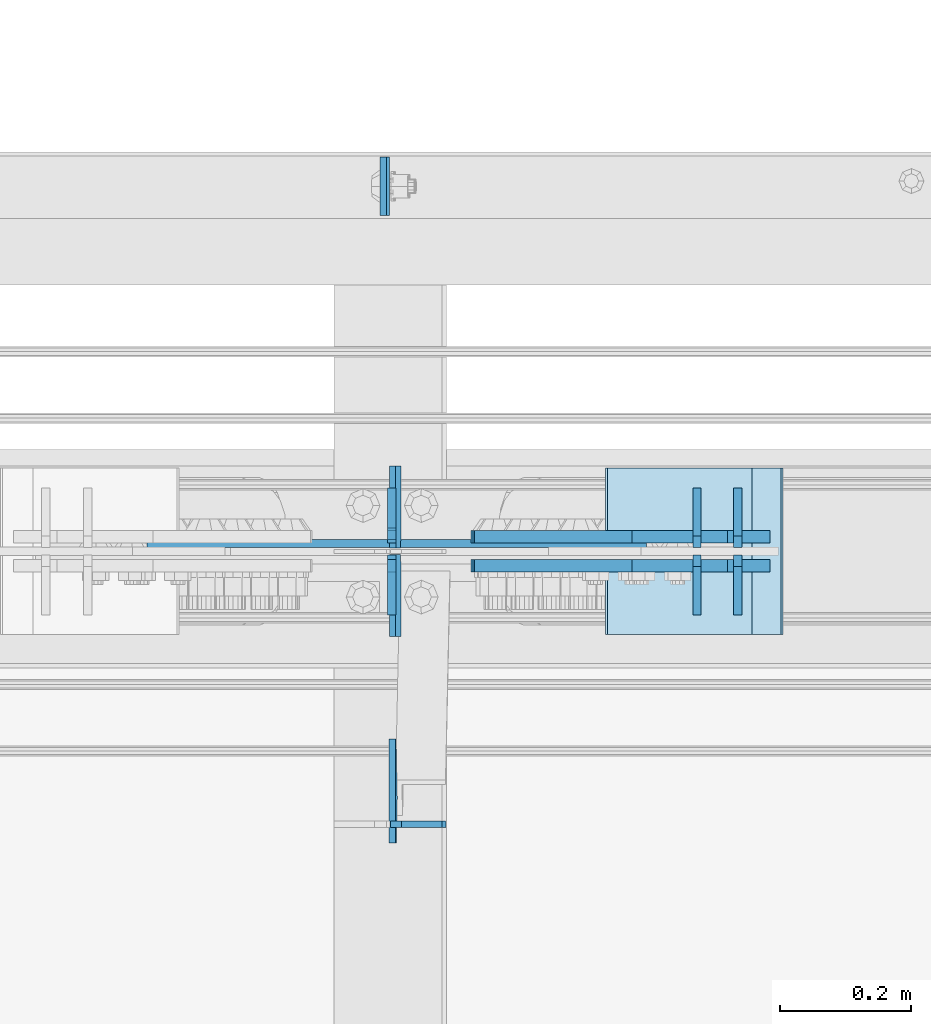
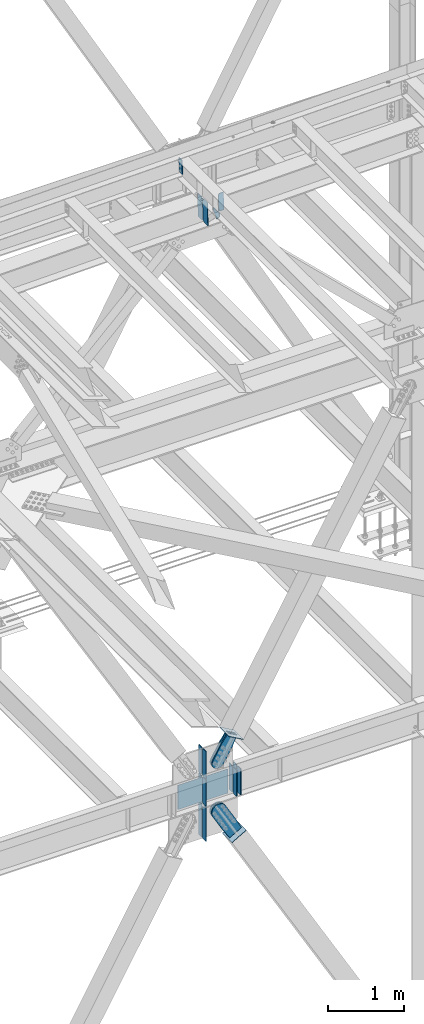
# One storey, part 3471 of 3843: 22 plates, 10 elements without a shape of their own.
"""IFC2X3 building model written with IfcOpenShell, lengths in millimetres."""

from ifc_helpers import new_model, si_unit, frame, origin_with_axes, place, context, subcontext, project, spatial, faceted_brep, material, type_object, element, aggregate, save


model = new_model("IFC2X3")

# Units and contexts
model_context = context("Model", 3, precision=1e-05, world=origin_with_axes())
body_context = subcontext(model_context, "Body", "Model", "MODEL_VIEW")
ifc_project = project(units=[si_unit("LENGTHUNIT", "METRE", prefix="MILLI"), si_unit("AREAUNIT", "SQUARE_METRE"), si_unit("VOLUMEUNIT", "CUBIC_METRE"), si_unit("MASSUNIT", "GRAM", prefix="KILO"), si_unit("TIMEUNIT", "SECOND"), si_unit("PLANEANGLEUNIT", "RADIAN"), si_unit("SOLIDANGLEUNIT", "STERADIAN"), si_unit("THERMODYNAMICTEMPERATUREUNIT", "DEGREE_CELSIUS"), si_unit("LUMINOUSINTENSITYUNIT", "LUMEN")], contexts=[model_context])

# Site, building, storey
site_placement = place(None, origin_with_axes())
site = spatial("IfcSite", under=ifc_project, at=site_placement, CompositionType="ELEMENT")
building_placement = place(site_placement, origin_with_axes())
building = spatial("IfcBuilding", under=site, at=building_placement, Name="Undefined", CompositionType="ELEMENT")
storey_placement = place(building_placement, origin_with_axes())
storey = spatial("IfcBuildingStorey", under=building, at=storey_placement, Name="Undefined", CompositionType="ELEMENT", Elevation=0.0)

# Assembly, plate
assembly_1_placement = place(storey_placement, origin_with_axes())
assembly_1 = element("IfcElementAssembly", 1, at=assembly_1_placement, inside=storey, Name="CHANNEL", AssemblyPlace="NOTDEFINED", PredefinedType="RIGID_FRAME")
ifc_material_1 = material(Name="STEEL/A572-50")
plate_type_1 = type_object("IfcPlateType", PredefinedType="NOTDEFINED")
plate_1_placement = place(assembly_1_placement, frame((52449.9878805814, 92816.3624116129, 46027.3749130814), z_axis=(1.85699999689158e-05, -0.999999999827578, 0.0), x_axis=(0.0211520550054438, 0.0, -0.999776270257025)))
plate_1 = element("IfcPlate", 2, at=plate_1_placement, type_object=plate_type_1, material=ifc_material_1, Name="PLATE", context=body_context, shape_type="Brep", body=[
    faceted_brep([(0.0, -4.76249999999709, 0.0), (0.0, -4.76249999999709, 88.9000015258789), (0.0, 4.76249999999709, 88.9000015258789), (0.0, 4.76249999999709, 0.0), (228.600006102781, -4.7625000004191, 88.9000015257589), (228.600006102781, 4.76249999954598, 88.9000015257443), (228.600006103079, -4.7625000004482, 7.27595761418343e-12), (228.600006103079, 4.76249999954598, -7.27595761418343e-12)], [[[0, 1, 2, 3]], [[1, 4, 5, 2]], [[4, 6, 7, 5]], [[6, 0, 3, 7]], [[5, 7, 3, 2]], [[6, 4, 1, 0]]]),
])
aggregate(assembly_1, [plate_1])

# Assembly, plates
assembly_2_placement = place(storey_placement, origin_with_axes())
assembly_2 = element("IfcElementAssembly", 3, at=assembly_2_placement, inside=storey, Name="BEAM", AssemblyPlace="NOTDEFINED", PredefinedType="RIGID_FRAME")
plate_type_2 = type_object("IfcPlateType", PredefinedType="NOTDEFINED")
plate_2_placement = place(assembly_2_placement, frame((52472.0350760633, 92084.525, 45357.7209272151), z_axis=(-0.0211520980073474, 0.0, 0.999776269347241), x_axis=(0.0, 1.0, 0.0)))
plate_2 = element("IfcPlate", 4, at=plate_2_placement, type_object=plate_type_2, material=ifc_material_1, Name="STIFFENER", context=body_context, shape_type="Brep", body=[
    faceted_brep([(0.0, -4.76249999999709, 0.0), (0.0, -4.76249999999709, 377.824999997538), (0.0, 4.76249999999709, 377.824999997538), (0.0, 4.76249999999709, 0.0), (103.187499618536, -4.76249999999709, 377.824999997538), (103.187499618536, 4.76249999999709, 377.824999997538), (125.412500000006, -4.76249999999709, 355.599999616068), (125.412500000006, 4.76249999999709, 355.599999616068), (125.412500000006, -4.76249999999709, 22.2250003814697), (125.412500000006, 4.76249999999709, 22.2250003814697), (103.187499618536, -4.76249999999709, 0.0), (103.187499618536, 4.76249999999709, 0.0)], [[[0, 1, 2, 3]], [[1, 4, 5, 2]], [[4, 6, 7, 5]], [[6, 8, 9, 7]], [[8, 10, 11, 9]], [[10, 0, 3, 11]], [[5, 7, 9, 11, 3, 2]], [[10, 8, 6, 4, 1, 0]]]),
])
plate_3_placement = place(assembly_2_placement, frame((52472.0350760633, 92219.4625, 45357.7209272151), z_axis=(-0.0211520980073474, 0.0, 0.999776269347241), x_axis=(0.0, 1.0, 0.0)))
plate_3 = element("IfcPlate", 5, at=plate_3_placement, type_object=plate_type_2, material=ifc_material_1, Name="STIFFENER", context=body_context, shape_type="Brep", body=[
    faceted_brep([(0.0, -4.76249999999709, 22.2250003814697), (0.0, -4.76249999999709, 355.599999616068), (0.0, 4.76249999999709, 355.599999616068), (0.0, 4.76249999999709, 22.2250003814697), (22.2250003814697, -4.76249999999709, 377.824999997538), (22.2250003814697, 4.76249999999709, 377.824999997538), (125.412500000006, -4.76249999999709, 377.824999997538), (125.412500000006, 4.76249999999709, 377.824999997538), (125.412500000006, -4.76249999999709, 0.0), (125.412500000006, 4.76249999999709, 0.0), (22.2250003814697, -4.76249999999709, 0.0), (22.2250003814697, 4.76249999999709, 0.0)], [[[0, 1, 2, 3]], [[1, 4, 5, 2]], [[4, 6, 7, 5]], [[6, 8, 9, 7]], [[8, 10, 11, 9]], [[10, 0, 3, 11]], [[5, 7, 9, 11, 3, 2]], [[10, 8, 6, 4, 1, 0]]]),
])
aggregate(assembly_2, [plate_2, plate_3])

assembly_3_placement = place(storey_placement, origin_with_axes())
assembly_3 = element("IfcElementAssembly", 6, at=assembly_3_placement, inside=storey, Name="BEAM", AssemblyPlace="NOTDEFINED", PredefinedType="RIGID_FRAME")
plate_type_3 = type_object("IfcPlateType", PredefinedType="NOTDEFINED")
plate_4_placement = place(assembly_3_placement, frame((52990.8604782097, 92220.25625, 35990.2125), z_axis=(0.0, 1.0, 0.0), x_axis=(0.0, 0.0, 1.0)))
plate_4 = element("IfcPlate", 7, at=plate_4_placement, type_object=plate_type_3, material=ifc_material_1, Name="CB_BEAM", context=body_context, shape_type="Brep", body=[
    faceted_brep([(0.0, -6.34999999999854, 17.4624996185303), (0.0, -6.34999999999854, 91.28125), (0.0, 6.34999999999854, 91.28125), (0.0, 6.34999999999854, 17.4624996185303), (425.449999999997, -6.34999999999854, 91.28125), (425.449999999997, 6.34999999999854, 91.28125), (425.449999999997, -6.34999999999854, 17.4624996185303), (425.449999999997, 6.34999999999854, 17.4624996185303), (407.987500381467, -6.34999999999854, 0.0), (407.987500381467, 6.34999999999854, 0.0), (17.4624996185303, -6.34999999999854, 0.0), (17.4624996185303, 6.34999999999854, 0.0)], [[[0, 1, 2, 3]], [[1, 4, 5, 2]], [[4, 6, 7, 5]], [[6, 8, 9, 7]], [[8, 10, 11, 9]], [[10, 0, 3, 11]], [[5, 7, 9, 11, 3, 2]], [[10, 8, 6, 4, 1, 0]]]),
])
plate_5_placement = place(assembly_3_placement, frame((52990.8604782097, 92209.14375, 35990.2125), z_axis=(0.0, -1.0, 0.0), x_axis=(0.0, 0.0, 1.0)))
plate_5 = element("IfcPlate", 8, at=plate_5_placement, type_object=plate_type_3, material=ifc_material_1, Name="CB_BEAM", context=body_context, shape_type="Brep", body=[
    faceted_brep([(0.0, -6.34999999999854, 17.4624996185303), (0.0, -6.34999999999854, 91.28125), (0.0, 6.34999999999854, 91.28125), (0.0, 6.34999999999854, 17.4624996185303), (425.449999999997, -6.34999999999854, 91.28125), (425.449999999997, 6.34999999999854, 91.28125), (425.449999999997, -6.34999999999854, 17.4624996185303), (425.449999999997, 6.34999999999854, 17.4624996185303), (407.987500381467, -6.34999999999854, 0.0), (407.987500381467, 6.34999999999854, 0.0), (17.4624996185303, -6.34999999999854, 0.0), (17.4624996185303, 6.34999999999854, 0.0)], [[[0, 1, 2, 3]], [[1, 4, 5, 2]], [[4, 6, 7, 5]], [[6, 8, 9, 7]], [[8, 10, 11, 9]], [[10, 0, 3, 11]], [[5, 7, 9, 11, 3, 2]], [[10, 8, 6, 4, 1, 0]]]),
])
plate_6_placement = place(assembly_3_placement, frame((52928.7637189592, 92220.25625, 35990.2125), z_axis=(0.0, 1.0, 0.0), x_axis=(0.0, 0.0, 1.0)))
plate_6 = element("IfcPlate", 9, at=plate_6_placement, type_object=plate_type_3, material=ifc_material_1, Name="CB_BEAM", context=body_context, shape_type="Brep", body=[
    faceted_brep([(0.0, -6.34999999999854, 17.4624996185303), (0.0, -6.34999999999854, 91.28125), (0.0, 6.34999999999854, 91.28125), (0.0, 6.34999999999854, 17.4624996185303), (425.449999999997, -6.34999999999854, 91.28125), (425.449999999997, 6.34999999999854, 91.28125), (425.449999999997, -6.34999999999854, 17.4624996185303), (425.449999999997, 6.34999999999854, 17.4624996185303), (407.987500381467, -6.34999999999854, 0.0), (407.987500381467, 6.34999999999854, 0.0), (17.4624996185303, -6.34999999999854, 0.0), (17.4624996185303, 6.34999999999854, 0.0)], [[[0, 1, 2, 3]], [[1, 4, 5, 2]], [[4, 6, 7, 5]], [[6, 8, 9, 7]], [[8, 10, 11, 9]], [[10, 0, 3, 11]], [[5, 7, 9, 11, 3, 2]], [[10, 8, 6, 4, 1, 0]]]),
])
plate_7_placement = place(assembly_3_placement, frame((52928.7637189592, 92209.14375, 35990.2125), z_axis=(0.0, -1.0, 0.0), x_axis=(0.0, 0.0, 1.0)))
plate_7 = element("IfcPlate", 10, at=plate_7_placement, type_object=plate_type_3, material=ifc_material_1, Name="CB_BEAM", context=body_context, shape_type="Brep", body=[
    faceted_brep([(0.0, -6.34999999999854, 17.4624996185303), (0.0, -6.34999999999854, 91.28125), (0.0, 6.34999999999854, 91.28125), (0.0, 6.34999999999854, 17.4624996185303), (425.449999999997, -6.34999999999854, 91.28125), (425.449999999997, 6.34999999999854, 91.28125), (425.449999999997, -6.34999999999854, 17.4624996185303), (425.449999999997, 6.34999999999854, 17.4624996185303), (407.987500381467, -6.34999999999854, 0.0), (407.987500381467, 6.34999999999854, 0.0), (17.4624996185303, -6.34999999999854, 0.0), (17.4624996185303, 6.34999999999854, 0.0)], [[[0, 1, 2, 3]], [[1, 4, 5, 2]], [[4, 6, 7, 5]], [[6, 8, 9, 7]], [[8, 10, 11, 9]], [[10, 0, 3, 11]], [[5, 7, 9, 11, 3, 2]], [[10, 8, 6, 4, 1, 0]]]),
])
plate_8_placement = place(assembly_3_placement, frame((52462.90625, 92209.14375, 35990.2125), z_axis=(0.0, -1.0, 0.0), x_axis=(0.0, 0.0, 1.0)))
plate_8 = element("IfcPlate", 11, at=plate_8_placement, type_object=plate_type_3, material=ifc_material_1, Name="CB_BEAM", context=body_context, shape_type="Brep", body=[
    faceted_brep([(0.0, -6.34999999999854, 17.4624996185303), (0.0, -6.34999999999854, 91.28125), (0.0, 6.34999999999854, 91.28125), (0.0, 6.34999999999854, 17.4624996185303), (425.449999999997, -6.34999999999854, 91.28125), (425.449999999997, 6.34999999999854, 91.28125), (425.449999999997, -6.34999999999854, 17.4624996185303), (425.449999999997, 6.34999999999854, 17.4624996185303), (407.987500381467, -6.34999999999854, 0.0), (407.987500381467, 6.34999999999854, 0.0), (17.4624996185303, -6.34999999999854, 0.0), (17.4624996185303, 6.34999999999854, 0.0)], [[[0, 1, 2, 3]], [[1, 4, 5, 2]], [[4, 6, 7, 5]], [[6, 8, 9, 7]], [[8, 10, 11, 9]], [[10, 0, 3, 11]], [[5, 7, 9, 11, 3, 2]], [[10, 8, 6, 4, 1, 0]]]),
])
plate_type_4 = type_object("IfcPlateType", PredefinedType="NOTDEFINED")
plate_9_placement = place(assembly_3_placement, frame((52089.5207377025, 92226.6062499983, 36006.0874996181), z_axis=(0.0, 0.0, 1.0), x_axis=(1.0, 0.0, 0.0)))
plate_9 = element("IfcPlate", 12, at=plate_9_placement, type_object=plate_type_4, material=ifc_material_1, Name="PLATE", context=body_context, shape_type="Brep", body=[
    faceted_brep([(0.0, -6.3499999046162, 0.0), (0.0, 6.35000000000582, 7.33234923778218), (761.999999999964, 6.35000000000582, 7.33234923778218), (761.999999999964, -6.35000000000582, 4.22005541622639e-10), (761.999999999978, -6.35000000000582, 393.700000763354), (0.0, -6.34999999999854, 393.700012207031), (1.45519152283669e-11, 6.35000000000582, 386.367651525979), (761.999999999978, 6.35000000000582, 386.367651525979)], [[[0, 1, 2, 3]], [[0, 3, 4, 5]], [[1, 0, 5, 6]], [[2, 1, 6, 7]], [[3, 2, 7, 4]], [[6, 5, 4, 7]]]),
])

# Assembly, plate
assembly_4_placement = place(storey_placement, origin_with_axes())
assembly_4 = element("IfcElementAssembly", 13, at=assembly_4_placement, inside=storey, AssemblyPlace="NOTDEFINED", PredefinedType="RIGID_FRAME")
ifc_material_2 = material(Name="STEEL/A36")
plate_type_5 = type_object("IfcPlateType", PredefinedType="NOTDEFINED")
plate_10_placement = place(assembly_4_placement, frame((52940.6252918042, 92236.925, 36858.7164706586), z_axis=(-0.865635480884955, 0.0, 0.500674758933454), x_axis=(0.500674758933455, 0.0, 0.865635480884955)))
plate_10 = element("IfcPlate", 14, at=plate_10_placement, type_object=plate_type_5, material=ifc_material_2, context=body_context, shape_type="Brep", body=[
    faceted_brep([(0.0, -9.52500000000146, 0.0), (-101.599999999351, -9.52499999999418, -12.3260213857429), (-101.599999999351, 9.52499999999418, -12.3260213857429), (0.0, 9.52500000000146, 0.0), (-364.729297663791, -9.52499999999418, -12.3260213864851), (-364.729297663791, 9.52499999999418, -12.3260213864851), (-401.787405129209, -9.52499999999418, -4.95470550008758), (-401.787405129209, 9.52499999999418, -4.95470550008758), (-433.203751665707, -9.52499999999418, 16.0370261367789), (-433.203751665707, 9.52499999999418, 16.0370261367789), (-454.195483303061, -9.52499999999418, 47.4533726729569), (-454.195483303061, 9.52499999999418, 47.4533726729569), (-461.566799190045, -9.52499999999418, 84.5114770857908), (-461.566799190045, 9.52499999999418, 84.5114770857908), (-454.195483303822, -9.52499999999418, 121.569584551733), (-454.195483303822, 9.52499999999418, 121.569584551733), (-433.203751666773, -9.52499999999418, 152.985931088682), (-433.203751666773, 9.52499999999418, 152.985931088682), (-401.787405130151, -9.52499999999418, 173.977662726218), (-401.787405130151, 9.52499999999418, 173.977662726218), (-364.729299191746, -9.52499999999418, 181.348978613009), (-364.729299191746, 9.52499999999418, 181.348978613009), (-101.600000001839, -9.52499999999418, 181.348978613736), (-101.600000001839, 9.52499999999418, 181.348978613736), (-2.16823536902666e-09, -9.52499999999418, 169.022957228546), (-2.16823536902666e-09, 9.52499999999418, 169.022957228546), (69.8499999974956, -9.52499999999418, 169.02295722875), (69.8499999974956, 9.52499999999418, 169.02295722875), (69.8499999979995, -9.52499999999418, -4.00177668780088e-10), (69.8499999979995, 9.52499999999418, -4.00177668780088e-10)], [[[0, 1, 2, 3]], [[1, 4, 5, 2]], [[4, 6, 7, 5]], [[6, 8, 9, 7]], [[8, 10, 11, 9]], [[10, 12, 13, 11]], [[12, 14, 15, 13]], [[14, 16, 17, 15]], [[16, 18, 19, 17]], [[18, 20, 21, 19]], [[20, 22, 23, 21]], [[22, 24, 25, 23]], [[24, 26, 27, 25]], [[26, 28, 29, 27]], [[28, 0, 3, 29]], [[5, 7, 9, 11, 13, 15, 17, 19, 21, 23, 25, 27, 29, 3, 2]], [[28, 26, 24, 22, 20, 18, 16, 14, 12, 10, 8, 6, 4, 1, 0]]]),
])
aggregate(assembly_4, [plate_10])

assembly_5_placement = place(storey_placement, origin_with_axes())
assembly_5 = element("IfcElementAssembly", 15, at=assembly_5_placement, inside=storey, AssemblyPlace="NOTDEFINED", PredefinedType="RIGID_FRAME")
plate_11_placement = place(assembly_5_placement, frame((52940.6252918042, 92192.475, 36858.7164706586), z_axis=(-0.865635480884955, 0.0, 0.500674758933454), x_axis=(0.500674758933455, 0.0, 0.865635480884955)))
plate_11 = element("IfcPlate", 16, at=plate_11_placement, type_object=plate_type_5, material=ifc_material_2, context=body_context, shape_type="Brep", body=[
    faceted_brep([(0.0, -9.52500000000146, 0.0), (-101.599999999351, -9.52499999999418, -12.3260213857429), (-101.599999999351, 9.52499999999418, -12.3260213857429), (0.0, 9.52500000000146, 0.0), (-364.729297663791, -9.52499999999418, -12.3260213864851), (-364.729297663791, 9.52499999999418, -12.3260213864851), (-401.787405129209, -9.52499999999418, -4.95470550008758), (-401.787405129209, 9.52499999999418, -4.95470550008758), (-433.203751665707, -9.52499999999418, 16.0370261367789), (-433.203751665707, 9.52499999999418, 16.0370261367789), (-454.195483303061, -9.52499999999418, 47.4533726729569), (-454.195483303061, 9.52499999999418, 47.4533726729569), (-461.566799190045, -9.52499999999418, 84.5114770857908), (-461.566799190045, 9.52499999999418, 84.5114770857908), (-454.195483303822, -9.52499999999418, 121.569584551733), (-454.195483303822, 9.52499999999418, 121.569584551733), (-433.203751666773, -9.52499999999418, 152.985931088682), (-433.203751666773, 9.52499999999418, 152.985931088682), (-401.787405130151, -9.52499999999418, 173.977662726218), (-401.787405130151, 9.52499999999418, 173.977662726218), (-364.729299191746, -9.52499999999418, 181.348978613009), (-364.729299191746, 9.52499999999418, 181.348978613009), (-101.600000001839, -9.52499999999418, 181.348978613736), (-101.600000001839, 9.52499999999418, 181.348978613736), (-2.16823536902666e-09, -9.52499999999418, 169.022957228546), (-2.16823536902666e-09, 9.52499999999418, 169.022957228546), (69.8499999974956, -9.52499999999418, 169.02295722875), (69.8499999974956, 9.52499999999418, 169.02295722875), (69.8499999979995, -9.52499999999418, -4.00177668780088e-10), (69.8499999979995, 9.52499999999418, -4.00177668780088e-10)], [[[0, 1, 2, 3]], [[1, 4, 5, 2]], [[4, 6, 7, 5]], [[6, 8, 9, 7]], [[8, 10, 11, 9]], [[10, 12, 13, 11]], [[12, 14, 15, 13]], [[14, 16, 17, 15]], [[16, 18, 19, 17]], [[18, 20, 21, 19]], [[20, 22, 23, 21]], [[22, 24, 25, 23]], [[24, 26, 27, 25]], [[26, 28, 29, 27]], [[28, 0, 3, 29]], [[5, 7, 9, 11, 13, 15, 17, 19, 21, 23, 25, 27, 29, 3, 2]], [[28, 26, 24, 22, 20, 18, 16, 14, 12, 10, 8, 6, 4, 1, 0]]]),
])
aggregate(assembly_5, [plate_11])

assembly_6_placement = place(storey_placement, origin_with_axes())
assembly_6 = element("IfcElementAssembly", 17, at=assembly_6_placement, inside=storey, Name="Plate", AssemblyPlace="NOTDEFINED", PredefinedType="RIGID_FRAME")
plate_type_6 = type_object("IfcPlateType", PredefinedType="NOTDEFINED")
plate_12_placement = place(assembly_6_placement, frame((52838.0986316558, 92341.7, 35293.760323398), z_axis=(0.867738530399936, 0.0, 0.497020968229068), x_axis=(0.0, -1.0, 0.0)))
plate_12 = element("IfcPlate", 18, at=plate_12_placement, type_object=plate_type_6, material=ifc_material_2, Name="Plate", context=body_context, shape_type="Brep", body=[
    faceted_brep([(0.0, -3.17499999999927, 0.0), (0.0, -3.17499999965185, 254.000000005151), (0.0, 3.17500000035216, 254.000000005166), (0.0, 3.17499999999927, 0.0), (254.0, -3.17499999965185, 254.000000005151), (254.0, 3.17500000035216, 254.000000005166), (254.0, -3.17500000000291, 0.0), (254.0, 3.17499999999927, 1.45519152283669e-11)], [[[0, 1, 2, 3]], [[1, 4, 5, 2]], [[4, 6, 7, 5]], [[6, 0, 3, 7]], [[5, 7, 3, 2]], [[6, 4, 1, 0]]]),
])
aggregate(assembly_6, [plate_12])

assembly_7_placement = place(storey_placement, origin_with_axes())
assembly_7 = element("IfcElementAssembly", 19, at=assembly_7_placement, inside=storey, Name="Plate", AssemblyPlace="NOTDEFINED", PredefinedType="RIGID_FRAME")
plate_13_placement = place(assembly_7_placement, frame((53010.7873533458, 92087.7, 36895.1597859447), z_axis=(-0.865635480884955, 0.0, 0.500674758933454), x_axis=(0.0, 1.0, 0.0)))
plate_13 = element("IfcPlate", 20, at=plate_13_placement, type_object=plate_type_6, material=ifc_material_2, Name="Plate", context=body_context, shape_type="Brep", body=[
    faceted_brep([(0.0, -3.17499999999927, 0.0), (0.0, -3.17499999965185, 254.000000005151), (0.0, 3.17500000035216, 254.000000005166), (0.0, 3.17499999999927, 0.0), (254.0, -3.17499999965185, 254.000000005151), (254.0, 3.17500000035216, 254.000000005166), (254.0, -3.17500000000291, 0.0), (254.0, 3.17499999999927, 1.45519152283669e-11)], [[[0, 1, 2, 3]], [[1, 4, 5, 2]], [[4, 6, 7, 5]], [[6, 0, 3, 7]], [[5, 7, 3, 2]], [[6, 4, 1, 0]]]),
])
aggregate(assembly_7, [plate_13])

# Plate
plate_type_7 = type_object("IfcPlateType", PredefinedType="NOTDEFINED")
plate_14_placement = place(assembly_3_placement, frame((52462.9062480303, 92227.4, 35430.023437), z_axis=(0.0, 1.0, 0.0), x_axis=(0.0, 0.0, 1.0)))
plate_14 = element("IfcPlate", 21, at=plate_14_placement, type_object=plate_type_7, material=ifc_material_1, Name="CB", context=body_context, shape_type="Brep", body=[
    faceted_brep([(0.0, -6.3499999046162, 0.0), (0.0, -6.34999999999854, 84.1374999999971), (0.0, 6.34999999999854, 84.1374999999971), (7.27595761418343e-12, 6.3499999046162, 0.0), (539.629933223121, -6.34999999999854, 84.1374999999971), (539.629933223121, 6.34999999999854, 84.1374999999971), (539.629933223121, -6.34999999999854, 19.0499992370605), (539.629933223121, 6.34999999999854, 19.0499992370605), (520.57993398606, -6.34999999999854, 0.0), (520.57993398606, 6.34999999999854, 0.0)], [[[0, 1, 2, 3]], [[1, 4, 5, 2]], [[4, 6, 7, 5]], [[6, 8, 9, 7]], [[8, 0, 3, 9]], [[5, 7, 9, 3, 2]], [[8, 6, 4, 1, 0]]]),
])

plate_15_placement = place(assembly_3_placement, frame((52462.9062480303, 92202.0, 35430.023437), z_axis=(0.0, -1.0, 0.0), x_axis=(0.0, 0.0, 1.0)))
plate_15 = element("IfcPlate", 22, at=plate_15_placement, type_object=plate_type_7, material=ifc_material_1, Name="CB", context=body_context, shape_type="Brep", body=[
    faceted_brep([(0.0, -6.3499999046162, 0.0), (0.0, -6.34999999999854, 84.1374999999971), (0.0, 6.34999999999854, 84.1374999999971), (7.27595761418343e-12, 6.3499999046162, 0.0), (539.629933223121, -6.34999999999854, 84.1374999999971), (539.629933223121, 6.34999999999854, 84.1374999999971), (539.629933223121, -6.34999999999854, 19.0499992370605), (539.629933223121, 6.34999999999854, 19.0499992370605), (520.57993398606, -6.34999999999854, 0.0), (520.57993398606, 6.34999999999854, 0.0)], [[[0, 1, 2, 3]], [[1, 4, 5, 2]], [[4, 6, 7, 5]], [[6, 8, 9, 7]], [[8, 0, 3, 9]], [[5, 7, 9, 3, 2]], [[8, 6, 4, 1, 0]]]),
])

plate_16_placement = place(assembly_3_placement, frame((52462.90625, 92227.4, 36436.3), z_axis=(0.0, 1.0, 0.0), x_axis=(0.0, 0.0, 1.0)))
plate_16 = element("IfcPlate", 23, at=plate_16_placement, type_object=plate_type_7, material=ifc_material_1, Name="CB", context=body_context, shape_type="Brep", body=[
    faceted_brep([(0.0, -6.34999999999854, 19.0499992370605), (0.0, -6.34999999999854, 84.1374999999971), (0.0, 6.34999999999854, 84.1374999999971), (0.0, 6.34999999999854, 19.0499992370605), (437.981901240615, -6.34999999999854, 84.1374999999971), (437.981901240615, 6.34999999999854, 84.1374999999971), (437.981901240615, -6.34999999999854, 0.0), (437.981901240615, 6.34999999999854, 0.0), (19.0499992370605, -6.34999999999854, 0.0), (19.0499992370605, 6.34999999999854, 0.0)], [[[0, 1, 2, 3]], [[1, 4, 5, 2]], [[4, 6, 7, 5]], [[6, 8, 9, 7]], [[8, 0, 3, 9]], [[5, 7, 9, 3, 2]], [[8, 6, 4, 1, 0]]]),
])

plate_17_placement = place(assembly_3_placement, frame((52462.90625, 92202.0, 36436.3), z_axis=(0.0, -1.0, 0.0), x_axis=(0.0, 0.0, 1.0)))
plate_17 = element("IfcPlate", 24, at=plate_17_placement, type_object=plate_type_7, material=ifc_material_1, Name="CB", context=body_context, shape_type="Brep", body=[
    faceted_brep([(0.0, -6.34999999999854, 19.0499992370605), (0.0, -6.34999999999854, 84.1374999999971), (0.0, 6.34999999999854, 84.1374999999971), (0.0, 6.34999999999854, 19.0499992370605), (437.981901240615, -6.34999999999854, 84.1374999999971), (437.981901240615, 6.34999999999854, 84.1374999999971), (437.981901240615, -6.34999999999854, 0.0), (437.981901240615, 6.34999999999854, 0.0), (19.0499992370605, -6.34999999999854, 0.0), (19.0499992370605, 6.34999999999854, 0.0)], [[[0, 1, 2, 3]], [[1, 4, 5, 2]], [[4, 6, 7, 5]], [[6, 8, 9, 7]], [[8, 0, 3, 9]], [[5, 7, 9, 3, 2]], [[8, 6, 4, 1, 0]]]),
])

# Assembly, plate
assembly_8_placement = place(storey_placement, origin_with_axes())
assembly_8 = element("IfcElementAssembly", 25, at=assembly_8_placement, inside=storey, AssemblyPlace="NOTDEFINED", PredefinedType="RIGID_FRAME")
plate_type_8 = type_object("IfcPlateType", PredefinedType="NOTDEFINED")
plate_18_placement = place(assembly_8_placement, frame((53005.4015828315, 92236.925, 35466.4253250437), z_axis=(-0.867738530399938, 0.0, -0.497020968229065), x_axis=(0.497020968229067, 0.0, -0.867738530399936)))
plate_18 = element("IfcPlate", 26, at=plate_18_placement, type_object=plate_type_8, material=ifc_material_2, context=body_context, shape_type="Brep", body=[
    faceted_brep([(0.0, -9.52500000000146, 0.0), (-101.600000000224, -9.52499999999418, -8.71915661533421), (-101.600000000224, 9.52499999999418, -8.71915661533421), (0.0, 9.52500000000146, 0.0), (-441.169864343115, -9.52499999999418, -8.71915661469393), (-441.169864343115, 9.52499999999418, -8.71915661469393), (-484.303071297451, -9.52499999999418, -0.139428306654736), (-484.303071297451, 9.52499999999418, -0.139428306654736), (-520.86963849645, -9.52499999999418, 24.2935707578508), (-520.86963849645, 9.52499999999418, 24.2935707578508), (-545.302637560817, -9.52499999999418, 60.8601379569373), (-545.302637560817, 9.52499999999418, 60.8601379569373), (-553.882365868703, -9.52499999999418, 103.993341860187), (-553.882365868703, 9.52499999999418, 103.993341860187), (-545.302637560671, -9.52499999999418, 147.126548814522), (-545.302637560671, 9.52499999999418, 147.126548814522), (-520.869638496166, -9.52499999999418, 183.693116013514), (-520.869638496166, 9.52499999999418, 183.693116013514), (-484.303071297072, -9.52499999999418, 208.126115077888), (-484.303071297072, 9.52499999999418, 208.126115077888), (-441.16986586828, -9.52499999999418, 216.705843385775), (-441.16986586828, 9.52499999999418, 216.705843385775), (-101.599999999817, -9.52499999999418, 216.705843385134), (-101.599999999817, 9.52499999999418, 216.705843385134), (-1.45519152283669e-11, -9.52499999999418, 207.986686767843), (-1.45519152283669e-11, 9.52499999999418, 207.986686767843), (69.8499999996129, -9.52499999999418, 207.986686767857), (69.8499999996129, 9.52499999999418, 207.986686767857), (69.8499999979995, -9.52499999999418, -4.00177668780088e-10), (69.8499999979995, 9.52499999999418, -4.00177668780088e-10)], [[[0, 1, 2, 3]], [[1, 4, 5, 2]], [[4, 6, 7, 5]], [[6, 8, 9, 7]], [[8, 10, 11, 9]], [[10, 12, 13, 11]], [[12, 14, 15, 13]], [[14, 16, 17, 15]], [[16, 18, 19, 17]], [[18, 20, 21, 19]], [[20, 22, 23, 21]], [[22, 24, 25, 23]], [[24, 26, 27, 25]], [[26, 28, 29, 27]], [[28, 0, 3, 29]], [[5, 7, 9, 11, 13, 15, 17, 19, 21, 23, 25, 27, 29, 3, 2]], [[28, 26, 24, 22, 20, 18, 16, 14, 12, 10, 8, 6, 4, 1, 0]]]),
])
aggregate(assembly_8, [plate_18])

assembly_9_placement = place(storey_placement, origin_with_axes())
assembly_9 = element("IfcElementAssembly", 27, at=assembly_9_placement, inside=storey, AssemblyPlace="NOTDEFINED", PredefinedType="RIGID_FRAME")
plate_19_placement = place(assembly_9_placement, frame((53005.4015828315, 92192.475, 35466.4253250437), z_axis=(-0.867738530399938, 0.0, -0.497020968229065), x_axis=(0.497020968229067, 0.0, -0.867738530399936)))
plate_19 = element("IfcPlate", 28, at=plate_19_placement, type_object=plate_type_8, material=ifc_material_2, context=body_context, shape_type="Brep", body=[
    faceted_brep([(0.0, -9.52500000000146, 0.0), (-101.600000000224, -9.52499999999418, -8.71915661533421), (-101.600000000224, 9.52499999999418, -8.71915661533421), (0.0, 9.52500000000146, 0.0), (-441.169864343115, -9.52499999999418, -8.71915661469393), (-441.169864343115, 9.52499999999418, -8.71915661469393), (-484.303071297451, -9.52499999999418, -0.139428306654736), (-484.303071297451, 9.52499999999418, -0.139428306654736), (-520.86963849645, -9.52499999999418, 24.2935707578508), (-520.86963849645, 9.52499999999418, 24.2935707578508), (-545.302637560817, -9.52499999999418, 60.8601379569373), (-545.302637560817, 9.52499999999418, 60.8601379569373), (-553.882365868703, -9.52499999999418, 103.993341860187), (-553.882365868703, 9.52499999999418, 103.993341860187), (-545.302637560671, -9.52499999999418, 147.126548814522), (-545.302637560671, 9.52499999999418, 147.126548814522), (-520.869638496166, -9.52499999999418, 183.693116013514), (-520.869638496166, 9.52499999999418, 183.693116013514), (-484.303071297072, -9.52499999999418, 208.126115077888), (-484.303071297072, 9.52499999999418, 208.126115077888), (-441.16986586828, -9.52499999999418, 216.705843385775), (-441.16986586828, 9.52499999999418, 216.705843385775), (-101.599999999817, -9.52499999999418, 216.705843385134), (-101.599999999817, 9.52499999999418, 216.705843385134), (-1.45519152283669e-11, -9.52499999999418, 207.986686767843), (-1.45519152283669e-11, 9.52499999999418, 207.986686767843), (69.8499999996129, -9.52499999999418, 207.986686767857), (69.8499999996129, 9.52499999999418, 207.986686767857), (69.8499999979995, -9.52499999999418, -4.00177668780088e-10), (69.8499999979995, 9.52499999999418, -4.00177668780088e-10)], [[[0, 1, 2, 3]], [[1, 4, 5, 2]], [[4, 6, 7, 5]], [[6, 8, 9, 7]], [[8, 10, 11, 9]], [[10, 12, 13, 11]], [[12, 14, 15, 13]], [[14, 16, 17, 15]], [[16, 18, 19, 17]], [[18, 20, 21, 19]], [[20, 22, 23, 21]], [[22, 24, 25, 23]], [[24, 26, 27, 25]], [[26, 28, 29, 27]], [[28, 0, 3, 29]], [[5, 7, 9, 11, 13, 15, 17, 19, 21, 23, 25, 27, 29, 3, 2]], [[28, 26, 24, 22, 20, 18, 16, 14, 12, 10, 8, 6, 4, 1, 0]]]),
])
aggregate(assembly_9, [plate_19])

# Plate
plate_type_9 = type_object("IfcPlateType", PredefinedType="NOTDEFINED")
plate_20_placement = place(assembly_3_placement, frame((52462.90625, 92232.95625, 35990.2125), z_axis=(0.0, 1.0, 0.0), x_axis=(0.0, 0.0, 1.0)))
plate_20 = element("IfcPlate", 29, at=plate_20_placement, type_object=plate_type_9, material=ifc_material_1, Name="CB_BEAM", context=body_context, shape_type="Brep", body=[
    faceted_brep([(0.0, -6.34999999999854, 17.4624996185303), (0.0, -6.34999999999854, 78.5812500000029), (0.0, 6.34999999999854, 78.5812500000029), (0.0, 6.34999999999854, 17.4624996185303), (425.449999999997, -6.34999999999854, 78.5812500000029), (425.449999999997, 6.34999999999854, 78.5812500000029), (425.449999999997, -6.34999999999854, 17.4624996185303), (425.449999999997, 6.34999999999854, 17.4624996185303), (407.987500381467, -6.34999999999854, 0.0), (407.987500381467, 6.34999999999854, 0.0), (17.4624996185303, -6.34999999999854, 0.0), (17.4624996185303, 6.34999999999854, 0.0)], [[[0, 1, 2, 3]], [[1, 4, 5, 2]], [[4, 6, 7, 5]], [[6, 8, 9, 7]], [[8, 10, 11, 9]], [[10, 0, 3, 11]], [[5, 7, 9, 11, 3, 2]], [[10, 8, 6, 4, 1, 0]]]),
])

aggregate(assembly_3, [plate_4, plate_5, plate_6, plate_7, plate_9, plate_20, plate_8, plate_14, plate_15, plate_16, plate_17])

# Assembly, plates
assembly_10_placement = place(storey_placement, origin_with_axes())
assembly_10 = element("IfcElementAssembly", 30, at=assembly_10_placement, inside=storey, Name="BEAM", AssemblyPlace="NOTDEFINED", PredefinedType="RIGID_FRAME")
plate_type_10 = type_object("IfcPlateType", PredefinedType="NOTDEFINED")
plate_21_placement = place(assembly_10_placement, frame((52463.6985866204, 91928.2967082497, 45755.3257925638), z_axis=(-1.58400502550648e-06, -0.999999997198664, 7.48342374863565e-05), x_axis=(0.0211520979903633, -7.4850999801065e-05, -0.999776266545638)))
plate_21 = element("IfcPlate", 31, at=plate_21_placement, type_object=plate_type_10, material=ifc_material_1, Name="PLATE", context=body_context, shape_type="Brep", body=[
    faceted_brep([(0.0, -4.76249999999709, 0.0), (-2.70811142399907e-08, -4.76250000001892, 158.560384385462), (-2.71029421128333e-08, 4.76249999997526, 158.560384385535), (0.0, 4.76249999999709, 0.0), (64.4096088781662, -4.76249999980064, 158.560384271579), (64.4096088781371, 4.76250000020082, 158.560384271637), (133.163860613262, -4.76249999955326, 89.7958391816646), (133.163860613233, 4.76250000044092, 89.7958391817228), (43.3545778650005, -4.76249999985157, 3.49245965480804e-10), (43.3545778649714, 4.76250000014261, 4.36557456851006e-10)], [[[0, 1, 2, 3]], [[1, 4, 5, 2]], [[4, 6, 7, 5]], [[6, 8, 9, 7]], [[8, 0, 3, 9]], [[5, 7, 9, 3, 2]], [[8, 6, 4, 1, 0]]]),
])
plate_type_11 = type_object("IfcPlateType", PredefinedType="NOTDEFINED")
plate_22_placement = place(assembly_10_placement, frame((52545.9964783177, 91797.9061497087, 45768.2546258971), z_axis=(-0.0211520979608104, 0.000867023000348128, 0.999775893399602), x_axis=(-0.999776269348226, -1.83429999838905e-05, -0.0211520900073297)))
plate_22 = element("IfcPlate", 32, at=plate_22_placement, type_object=plate_type_11, material=ifc_material_1, Name="STIFFENER", context=body_context, shape_type="Brep", body=[
    faceted_brep([(0.0, -4.76249999999709, 0.0), (-1.22236087918282e-09, -4.76250000040454, 288.924999996525), (-1.23691279441118e-09, 4.76249999957508, 288.92499999654), (0.0, 4.76249999999709, 0.0), (61.9125003798254, -4.76250000072469, 288.924999996685), (61.9125003798108, 4.76249999925494, 288.9249999967), (79.3749999983847, -4.76250000078289, 271.462500378249), (79.3749999983775, 4.76249999919673, 271.462500378271), (79.3749999994689, -4.7625000004191, 17.4624996186758), (79.3749999994543, 4.76249999954598, 17.4624996186976), (61.9125003810623, -4.76250000030268, 1.45519152283669e-10), (61.9125003810477, 4.76249999964784, 1.60071067512035e-10)], [[[0, 1, 2, 3]], [[1, 4, 5, 2]], [[4, 6, 7, 5]], [[6, 8, 9, 7]], [[8, 10, 11, 9]], [[10, 0, 3, 11]], [[5, 7, 9, 11, 3, 2]], [[10, 8, 6, 4, 1, 0]]]),
])
aggregate(assembly_10, [plate_22, plate_21])

save(model, "model.ifc")
